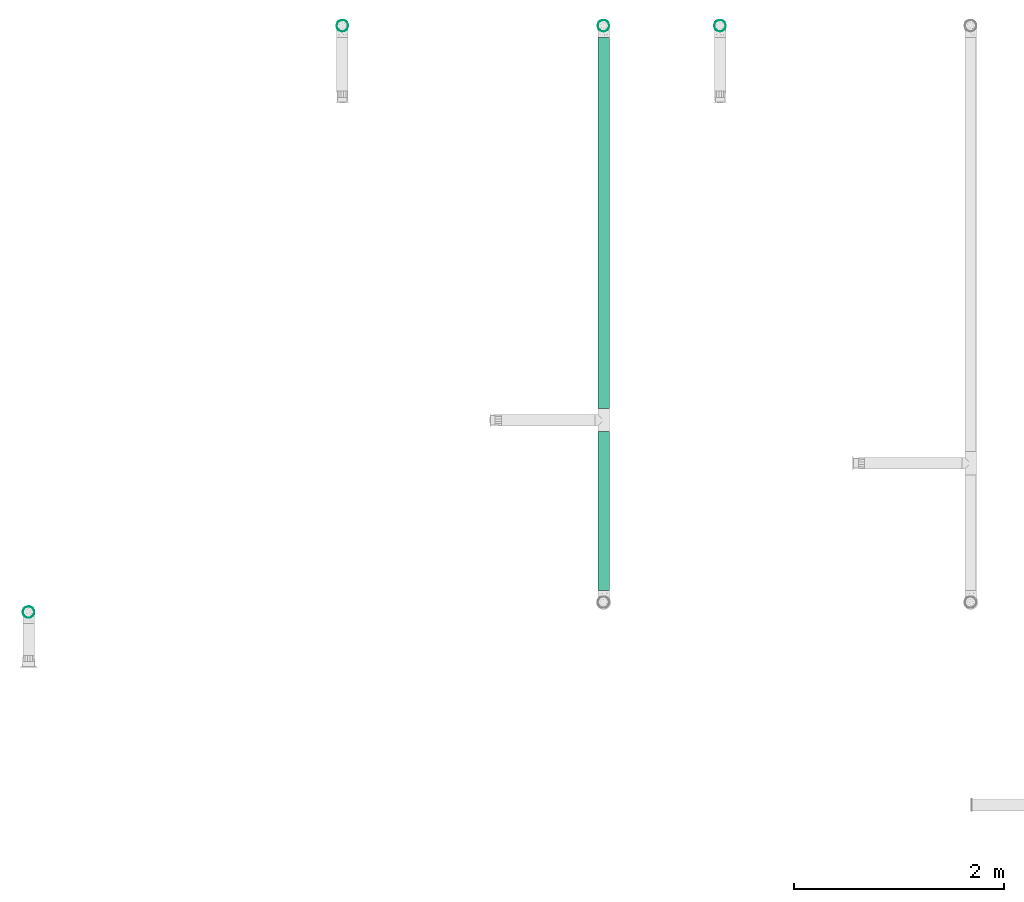
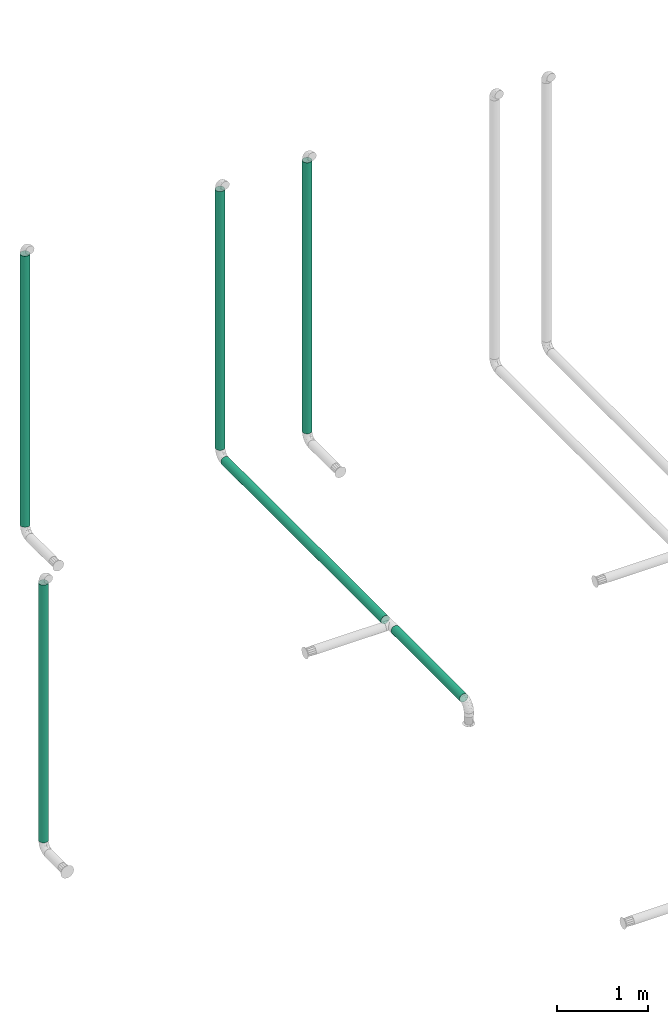
# One storey, part 3 of 115: 6 flow segments.
"""IFC2X3 building model written with IfcOpenShell, lengths in millimetres."""

from ifc_helpers import new_model, entity, si_unit, converted_unit, derived_unit, direction, frame, origin_with_axes, origin_2d_with_axis, place, context, subcontext, project, spatial, hollow_circle, extrude, source, transform, mapped, material, layer, layer_set, layer_usage, type_object, element, save


model = new_model("IFC2X3")

# Units and contexts
model_context = context("Model", 3, precision=1e-05, world=origin_with_axes(), true_north=direction((0.0, 1.0)))
body_context = subcontext(model_context, "Body", "Model", "MODEL_VIEW")
ifc_project = project(units=[si_unit("AREAUNIT", "SQUARE_METRE"), si_unit("VOLUMEUNIT", "CUBIC_METRE", prefix="DECI"), si_unit("TIMEUNIT", "SECOND"), si_unit("THERMODYNAMICTEMPERATUREUNIT", "DEGREE_CELSIUS"), si_unit("PRESSUREUNIT", "PASCAL"), si_unit("MASSUNIT", "GRAM", prefix="KILO"), si_unit("LENGTHUNIT", "METRE", prefix="MILLI"), si_unit("POWERUNIT", "WATT"), si_unit("ELECTRICCURRENTUNIT", "AMPERE"), si_unit("ELECTRICVOLTAGEUNIT", "VOLT"), derived_unit("VOLUMETRICFLOWRATEUNIT", [(si_unit("VOLUMEUNIT", "CUBIC_METRE", prefix="DECI"), 1), (si_unit("TIMEUNIT", "SECOND"), -1)]), derived_unit("LINEARVELOCITYUNIT", [(si_unit("LENGTHUNIT", "METRE"), 1), (si_unit("TIMEUNIT", "SECOND"), -1)]), derived_unit("MASSDENSITYUNIT", [(si_unit("MASSUNIT", "GRAM", prefix="KILO"), 1), (si_unit("VOLUMEUNIT", "CUBIC_METRE"), -1)]), converted_unit("PLANEANGLEUNIT", "DEGREE", entity("IfcRatioMeasure", 0.01745), si_unit("PLANEANGLEUNIT", "RADIAN"), dimensions=[0, 0, 0, 0, 0, 0, 0])], contexts=[model_context])

# Site, building, storey
site_placement = place(None, origin_with_axes())
site = spatial("IfcSite", under=ifc_project, at=site_placement, CompositionType="ELEMENT")
building_placement = place(site_placement, origin_with_axes())
building = spatial("IfcBuilding", under=site, at=building_placement, Name="mc-building", CompositionType="ELEMENT")
storey_placement = place(building_placement, frame((0.0, 0.0, 2950.0), z_axis=(0.0, 0.0, 1.0), x_axis=(1.0, 0.0, 0.0)))
storey = spatial("IfcBuildingStorey", under=building, at=storey_placement, Name="2. Korrus", CompositionType="ELEMENT", Elevation=2950.0)

# Flow segments
ifc_material = material(Name="FZ1")
ifc_layer = layer(ifc_material, 0.0)
ifc_layer_set = layer_set([ifc_layer], Name="FZ1")
ifc_layer_usage = layer_usage(ifc_layer_set, "AXIS1", "POSITIVE", 0.0)
duct_segment_type = type_object("IfcDuctSegmentType", PredefinedType="RIGIDSEGMENT")
shared_shape_1 = source(origin_with_axes(), body_context, "Body", "SweptSolid", [
    extrude(hollow_circle(Radius=55.0, WallThickness=2.0, at=origin_2d_with_axis()), frame((0.0, 0.0, 0.0), z_axis=(1.0, 0.0, 0.0), x_axis=(0.0, 1.0, 0.0)), (0.0, 0.0, 1.0), 3480.0),
])
flow_segment_1_placement = place(storey_placement, frame((7969.21808, 13663.57591, 2575.0), z_axis=(1.0, 0.0, 0.0), x_axis=(0.0, 0.0, 1.0)))
element("IfcFlowSegment", 1, at=flow_segment_1_placement, inside=storey, type_object=duct_segment_type, material=ifc_layer_usage, context=body_context, shape_type="MappedRepresentation", body=[
    mapped(shared_shape_1, transform((0.0, 0.0, 0.0), scale=1.0)),
])
shared_shape_2 = source(origin_with_axes(), body_context, "Body", "SweptSolid", [
    extrude(hollow_circle(Radius=55.0, WallThickness=2.0, at=origin_2d_with_axis()), frame((0.0, 0.0, 0.0), z_axis=(1.0, 0.0, 0.0), x_axis=(0.0, 1.0, 0.0)), (0.0, 0.0, 1.0), 1511.4),
])
flow_segment_2_placement = place(storey_placement, frame((7969.21808, 9805.0, 2465.0), z_axis=(0.0, 0.0, 1.0), x_axis=(0.0, -1.0, 0.0)))
element("IfcFlowSegment", 2, at=flow_segment_2_placement, inside=storey, type_object=duct_segment_type, material=ifc_layer_usage, context=body_context, shape_type="MappedRepresentation", body=[
    mapped(shared_shape_2, transform((0.0, 0.0, 0.0), scale=1.0)),
])
shared_shape_3 = source(origin_with_axes(), body_context, "Body", "SweptSolid", [
    extrude(hollow_circle(Radius=55.0, WallThickness=2.0, at=origin_2d_with_axis()), frame((0.0, 0.0, 0.0), z_axis=(1.0, 0.0, 0.0), x_axis=(0.0, 1.0, 0.0)), (0.0, 0.0, 1.0), 3528.6),
])
flow_segment_3_placement = place(storey_placement, frame((7969.21808, 13553.57591, 2465.0), z_axis=(0.0, 0.0, 1.0), x_axis=(0.0, -1.0, 0.0)))
element("IfcFlowSegment", 3, at=flow_segment_3_placement, inside=storey, type_object=duct_segment_type, material=ifc_layer_usage, context=body_context, shape_type="MappedRepresentation", body=[
    mapped(shared_shape_3, transform((0.0, 0.0, 0.0), scale=1.0)),
])
shared_shape_4 = source(origin_with_axes(), body_context, "Body", "SweptSolid", [
    extrude(hollow_circle(Radius=55.0, WallThickness=2.0, at=origin_2d_with_axis()), frame((0.0, 0.0, 0.0), z_axis=(1.0, 0.0, 0.0), x_axis=(0.0, 1.0, 0.0)), (0.0, 0.0, 1.0), 3645.0),
])
for number, where, z_axis, x_axis in (
    (4, (5487.14677, 13663.57591, 2410.0), (1.0, 0.0, 0.0), (0.0, 0.0, 1.0)),
    (5, (9076.57414, 13663.57591, 2410.0), (1.0, 0.0, 0.0), (0.0, 0.0, 1.0)),
):
    element("IfcFlowSegment", number, at=place(storey_placement, frame(where, z_axis=z_axis, x_axis=x_axis)), inside=storey, type_object=duct_segment_type, material=ifc_layer_usage, context=body_context, shape_type="MappedRepresentation", body=[
        mapped(shared_shape_4, transform((0.0, 0.0, 0.0), scale=1.0)),
    ])
shared_shape_5 = source(origin_with_axes(), body_context, "Body", "SweptSolid", [
    extrude(hollow_circle(Radius=55.0, WallThickness=2.0, at=origin_2d_with_axis()), frame((0.0, 0.0, 0.0), z_axis=(1.0, 0.0, 0.0), x_axis=(0.0, 1.0, 0.0)), (0.0, 0.0, 1.0), 3465.0),
])
flow_segment_4_placement = place(storey_placement, frame((2504.24801, 8089.38441, 2590.0), z_axis=(-1.0, 0.0, 0.0), x_axis=(0.0, 0.0, 1.0)))
element("IfcFlowSegment", 6, at=flow_segment_4_placement, inside=storey, type_object=duct_segment_type, material=ifc_layer_usage, context=body_context, shape_type="MappedRepresentation", body=[
    mapped(shared_shape_5, transform((0.0, 0.0, 0.0), scale=1.0)),
])

save(model, "model.ifc")
